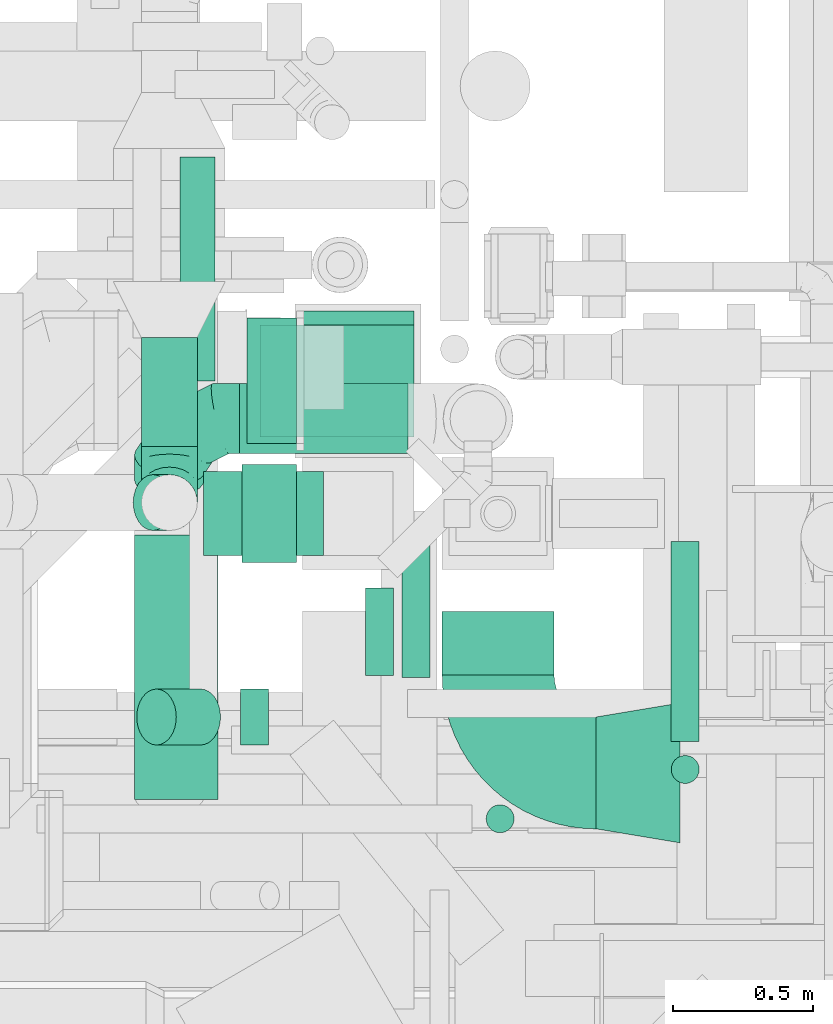
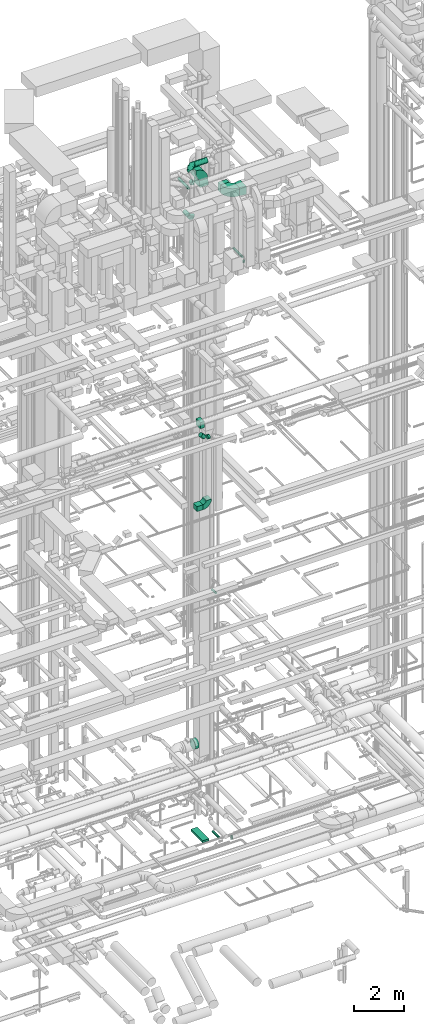
# One storey, part 234 of 337: 15 flow segments, 8 flow fittings.
"""IFC2X3 building model written with IfcOpenShell, lengths in millimetres."""

from ifc_helpers import new_model, entity, si_unit, converted_unit, derived_unit, direction, frame, frame_2d, origin, origin_2d_with_axis, place, context, subcontext, project, spatial, polyline, circle_curve, parameter, trimmed, segment, composite_curve, rectangle, circle, outline, extrude, faceted_brep, source, transform, mapped, material, type_object, type_shapes, element, save


model = new_model("IFC2X3")

# Units and contexts
model_context = context("Model", 3, precision=0.01, world=origin(), true_north=direction((6.12303176911189e-17, 1.0)))
body_context = subcontext(model_context, "Body", "Model", "MODEL_VIEW")
ifc_project = project(units=[si_unit("LENGTHUNIT", "METRE", prefix="MILLI"), si_unit("AREAUNIT", "SQUARE_METRE"), si_unit("VOLUMEUNIT", "CUBIC_METRE"), converted_unit("PLANEANGLEUNIT", "DEGREE", entity("IfcRatioMeasure", 0.0174532925199433), si_unit("PLANEANGLEUNIT", "RADIAN"), dimensions=[0, 0, 0, 0, 0, 0, 0]), si_unit("MASSUNIT", "GRAM", prefix="KILO"), derived_unit("MASSDENSITYUNIT", [(si_unit("MASSUNIT", "GRAM", prefix="KILO"), 1), (si_unit("LENGTHUNIT", "METRE"), -3)]), derived_unit("MOMENTOFINERTIAUNIT", [(si_unit("LENGTHUNIT", "METRE"), 4)]), si_unit("TIMEUNIT", "SECOND"), si_unit("FREQUENCYUNIT", "HERTZ"), si_unit("THERMODYNAMICTEMPERATUREUNIT", "DEGREE_CELSIUS"), derived_unit("THERMALTRANSMITTANCEUNIT", [(si_unit("MASSUNIT", "GRAM", prefix="KILO"), 1), (si_unit("THERMODYNAMICTEMPERATUREUNIT", "KELVIN"), -1), (si_unit("TIMEUNIT", "SECOND"), -3)]), derived_unit("VOLUMETRICFLOWRATEUNIT", [(si_unit("LENGTHUNIT", "METRE"), 3), (si_unit("TIMEUNIT", "SECOND"), -1)]), derived_unit("MASSFLOWRATEUNIT", [(si_unit("MASSUNIT", "GRAM", prefix="KILO"), 1), (si_unit("TIMEUNIT", "SECOND"), -1)]), derived_unit("ROTATIONALFREQUENCYUNIT", [(si_unit("TIMEUNIT", "SECOND"), -1)]), si_unit("ELECTRICCURRENTUNIT", "AMPERE"), si_unit("ELECTRICVOLTAGEUNIT", "VOLT"), si_unit("POWERUNIT", "WATT"), si_unit("FORCEUNIT", "NEWTON", prefix="KILO"), si_unit("ILLUMINANCEUNIT", "LUX"), si_unit("LUMINOUSFLUXUNIT", "LUMEN"), si_unit("LUMINOUSINTENSITYUNIT", "CANDELA"), derived_unit("USERDEFINED", [(si_unit("MASSUNIT", "GRAM", prefix="KILO"), -1), (si_unit("LENGTHUNIT", "METRE"), -2), (si_unit("TIMEUNIT", "SECOND"), 3), (si_unit("LUMINOUSFLUXUNIT", "LUMEN"), 1)]), derived_unit("LINEARVELOCITYUNIT", [(si_unit("LENGTHUNIT", "METRE"), 1), (si_unit("TIMEUNIT", "SECOND"), -1)]), si_unit("PRESSUREUNIT", "PASCAL"), derived_unit("USERDEFINED", [(si_unit("LENGTHUNIT", "METRE"), -2), (si_unit("MASSUNIT", "GRAM", prefix="KILO"), 1), (si_unit("TIMEUNIT", "SECOND"), -2)]), derived_unit("LINEARFORCEUNIT", [(si_unit("MASSUNIT", "GRAM", prefix="KILO"), 1), (si_unit("LENGTHUNIT", "METRE"), 1), (si_unit("TIMEUNIT", "SECOND"), -2), (si_unit("LENGTHUNIT", "METRE"), -1)]), derived_unit("PLANARFORCEUNIT", [(si_unit("MASSUNIT", "GRAM", prefix="KILO"), 1), (si_unit("LENGTHUNIT", "METRE"), 1), (si_unit("TIMEUNIT", "SECOND"), -2), (si_unit("LENGTHUNIT", "METRE"), -2)])], contexts=[model_context])

# Site, building, storey
site_placement = place(None, origin())
site = spatial("IfcSite", under=ifc_project, at=site_placement, CompositionType="ELEMENT")
building_placement = place(site_placement, origin())
building = spatial("IfcBuilding", under=site, at=building_placement, CompositionType="ELEMENT")
storey_placement = place(building_placement, origin())
storey = spatial("IfcBuildingStorey", under=building, at=storey_placement, CompositionType="ELEMENT", Elevation=0.0)

# Flow segments
duct_segment_type_1 = type_object("IfcDuctSegmentType", PredefinedType="NOTDEFINED")
flow_segment_1_placement = place(storey_placement, frame((58179.81, 9943.15, -625.0)))
element("IfcFlowSegment", 1, at=flow_segment_1_placement, inside=storey, type_object=duct_segment_type_1, context=body_context, shape_type="SweptSolid", body=[
    extrude(rectangle(XDim=944.720900000099, YDim=300.000000000001, at=origin_2d_with_axis()), frame((150.0, 472.36, 0.0), z_axis=(0.0, 0.0, 1.0), x_axis=(0.0, -1.0, 0.0)), (0.0, 0.0, 1.0), 100.0),
])
flow_segment_2_placement = place(storey_placement, frame((58427.28, 10815.63, 15000.0)))
element("IfcFlowSegment", 2, at=flow_segment_2_placement, inside=storey, type_object=duct_segment_type_1, context=body_context, shape_type="SweptSolid", body=[
    extrude(rectangle(XDim=278.095766639909, YDim=299.999999999999, at=origin_2d_with_axis()), frame((139.05, 150.0, 0.0), z_axis=(0.0, 0.0, 1.0), x_axis=(-1.0, 0.0, 0.0)), (0.0, 0.0, 1.0), 249.999999999999),
])
flow_segment_3_placement = place(storey_placement, frame((58564.44, 10789.64, 19034.58)))
element("IfcFlowSegment", 3, at=flow_segment_3_placement, inside=storey, type_object=duct_segment_type_1, context=body_context, shape_type="SweptSolid", body=[
    extrude(rectangle(XDim=195.941978523179, YDim=350.000000000001, at=origin_2d_with_axis()), frame((97.97, 175.0, 0.0)), (0.0, 0.0, 1.0), 300.000000000001),
])
flow_segment_4_placement = place(storey_placement, frame((59280.56, 10387.5, 30600.0)))
element("IfcFlowSegment", 4, at=flow_segment_4_placement, inside=storey, type_object=duct_segment_type_1, context=body_context, shape_type="SweptSolid", body=[
    extrude(rectangle(XDim=227.130410000165, YDim=399.999999999996, at=origin_2d_with_axis()), frame((200.0, 113.57, 0.0), z_axis=(0.0, 0.0, 1.0), x_axis=(0.0, 1.0, 0.0)), (0.0, 0.0, 1.0), 400.000000000004),
])
duct_segment_type_2 = type_object("IfcDuctSegmentType", PredefinedType="NOTDEFINED")
flow_segment_5_placement = place(storey_placement, frame((59436.1, 9821.97, -850.0)))
element("IfcFlowSegment", 5, at=flow_segment_5_placement, inside=storey, type_object=duct_segment_type_2, context=body_context, shape_type="SweptSolid", body=[
    extrude(circle(Radius=50.0, at=origin_2d_with_axis()), frame((51.6, 51.6, 0.0), z_axis=(0.0, 0.0, 1.0), x_axis=(-1.0, 0.0, 0.0)), (0.0, 0.0, 1.0), 170.0),
])
flow_segment_6_placement = place(storey_placement, frame((59135.22, 10378.7, -1026.6)))
element("IfcFlowSegment", 6, at=flow_segment_6_placement, inside=storey, type_object=duct_segment_type_2, context=body_context, shape_type="SweptSolid", body=[
    extrude(circle(Radius=50.0, at=origin_2d_with_axis()), frame((51.6, 0.0, 51.6), z_axis=(0.0, 1.0, 0.0), x_axis=(-1.0, 0.0, 0.0)), (0.0, 0.0, 1.0), 485.932210000001),
])
flow_segment_7_placement = place(storey_placement, frame((58582.17, 11212.98, 2939.23)))
element("IfcFlowSegment", 7, at=flow_segment_7_placement, inside=storey, type_object=duct_segment_type_2, context=body_context, shape_type="SweptSolid", body=[
    extrude(circle(Radius=225.0, at=origin_2d_with_axis()), frame((0.0, 226.6, 226.6), z_axis=(1.0, 0.0, 0.0), x_axis=(0.0, -1.0, 0.0)), (0.0, 0.0, 1.0), 177.728025964379),
])
flow_segment_8_placement = place(storey_placement, frame((59004.19, 10386.33, 10998.4)))
element("IfcFlowSegment", 8, at=flow_segment_8_placement, inside=storey, type_object=duct_segment_type_2, context=body_context, shape_type="SweptSolid", body=[
    extrude(circle(Radius=50.0, at=origin_2d_with_axis()), frame((51.6, 0.0, 51.6), z_axis=(0.0, 1.0, 0.0), x_axis=(-1.0, 0.0, 0.0)), (0.0, 0.0, 1.0), 313.317479908698),
])
flow_segment_9_placement = place(storey_placement, frame((58558.56, 10135.8, 18873.22)))
element("IfcFlowSegment", 9, at=flow_segment_9_placement, inside=storey, type_object=duct_segment_type_2, context=body_context, shape_type="SweptSolid", body=[
    extrude(circle(Radius=100.0, at=origin_2d_with_axis()), frame((0.0, 101.6, 101.6), z_axis=(1.0, 0.0, 0.0), x_axis=(0.0, 1.0, 0.0)), (0.0, 0.0, 1.0), 100.46959287631),
])
flow_segment_10_placement = place(storey_placement, frame((58186.8, 10135.8, 18961.09)))
element("IfcFlowSegment", 10, at=flow_segment_10_placement, inside=storey, type_object=duct_segment_type_2, context=body_context, shape_type="SweptSolid", body=[
    extrude(circle(Radius=100.0, at=origin_2d_with_axis()), frame((230.33, 101.6, 72.31), z_axis=(-0.707106781186548, 0.0, 0.707106781186548), x_axis=(0.0, 1.0, 0.0)), (0.0, 0.0, 1.0), 223.484445150657),
])
flow_segment_11_placement = place(storey_placement, frame((60097.92, 10149.93, 27248.4)))
element("IfcFlowSegment", 11, at=flow_segment_11_placement, inside=storey, type_object=duct_segment_type_2, context=body_context, shape_type="SweptSolid", body=[
    extrude(circle(Radius=50.0, at=origin_2d_with_axis()), frame((51.6, 0.0, 51.6), z_axis=(0.0, 1.0, 0.0), x_axis=(-1.0, 0.0, 0.0)), (0.0, 0.0, 1.0), 714.700000000041),
])
flow_segment_12_placement = place(storey_placement, frame((58340.94, 11438.43, 30433.4)))
element("IfcFlowSegment", 12, at=flow_segment_12_placement, inside=storey, type_object=duct_segment_type_2, context=body_context, shape_type="SweptSolid", body=[
    extrude(circle(Radius=62.5, at=origin_2d_with_axis()), frame((64.1, 0.0, 64.1), z_axis=(0.0, 1.0, 0.0), x_axis=(1.0, 0.0, 0.0)), (0.0, 0.0, 1.0), 800.886516975034),
])
flow_segment_13_placement = place(storey_placement, frame((58203.44, 11204.22, 29198.4)))
element("IfcFlowSegment", 13, at=flow_segment_13_placement, inside=storey, type_object=duct_segment_type_2, context=body_context, shape_type="SweptSolid", body=[
    extrude(circle(Radius=100.0, at=origin_2d_with_axis()), frame((101.6, 0.0, 101.6), z_axis=(0.0, 1.0, 0.0), x_axis=(-1.0, 0.0, 0.0)), (0.0, 0.0, 1.0), 390.042378695762),
])
flow_segment_14_placement = place(storey_placement, frame((60097.92, 9998.34, 27100.0)))
element("IfcFlowSegment", 14, at=flow_segment_14_placement, inside=storey, type_object=duct_segment_type_2, context=body_context, shape_type="SweptSolid", body=[
    extrude(circle(Radius=50.0, at=origin_2d_with_axis()), frame((51.6, 51.6, 0.0)), (0.0, 0.0, 1.0), 100.000000000003),
])
flow_segment_15_placement = place(storey_placement, frame((58555.03, 11177.59, 31573.0)))
element("IfcFlowSegment", 15, at=flow_segment_15_placement, inside=storey, type_object=duct_segment_type_2, context=body_context, shape_type="SweptSolid", body=[
    extrude(circle(Radius=125.0, at=origin_2d_with_axis()), frame((0.0, 126.6, 126.6), z_axis=(1.0, 0.0, 0.0), x_axis=(0.0, -1.0, 0.0)), (0.0, 0.0, 1.0), 603.905820001532),
])

# Flow fittings
ifc_material = material()
duct_fitting_type_1 = type_object("IfcDuctFittingType", PredefinedType="NOTDEFINED", material=ifc_material)
shared_shape_1 = source(origin(), body_context, "Body", "SweptSolid", [
    extrude(outline(polyline([(-189.06, -221.94), (115.08, -221.94), (180.84, 172.62), (-106.86, 271.26), (-189.06, -221.94)])), frame((150.0, 0.0, -200.0), z_axis=(0.0, 0.0, 1.0), x_axis=(0.986393923832144, 0.164398987305356, 0.0)), (0.0, 0.0, 1.0), 400.0),
])
type_shapes(duct_fitting_type_1, [shared_shape_1])
flow_fitting_1_placement = place(storey_placement, frame((60130.56, 10037.5, 30800.0), z_axis=(-1.35908083349201e-08, 0.0, 1.0), x_axis=(-1.0, 0.0, -1.35908083349201e-08)))
element("IfcFlowFitting", 16, at=flow_fitting_1_placement, inside=storey, type_object=duct_fitting_type_1, material=ifc_material, context=body_context, shape_type="MappedRepresentation", body=[
    mapped(shared_shape_1, transform((0.0, 0.0, 0.0), scale=1.0)),
])
duct_fitting_type_2 = type_object("IfcDuctFittingType", PredefinedType="NOTDEFINED", material=ifc_material)
shared_shape_2 = source(origin(), body_context, "Body", "SweptSolid", [
    extrude(outline(polyline([(-200.0, -150.0), (200.0, -150.0), (250.0, 150.0), (-250.0, 150.0), (-200.0, -150.0)])), frame((150.0, 0.0, -200.0), z_axis=(0.0, 0.0, 1.0), x_axis=(0.0, -1.0, 0.0)), (0.0, 0.0, 1.0), 400.0),
])
type_shapes(duct_fitting_type_2, [shared_shape_2])
flow_fitting_2_placement = place(storey_placement, frame((58979.9, 11439.32, 30850.0), z_axis=(1.0, 0.0, 0.0), x_axis=(0.0, 0.0, -1.0)))
element("IfcFlowFitting", 17, at=flow_fitting_2_placement, inside=storey, type_object=duct_fitting_type_2, material=ifc_material, context=body_context, shape_type="MappedRepresentation", body=[
    mapped(shared_shape_2, transform((0.0, 0.0, 0.0), scale=1.0)),
])
duct_fitting_type_3 = type_object("IfcDuctFittingType", PredefinedType="NOTDEFINED", material=ifc_material)
shared_shape_3 = source(origin(), body_context, "Body", "Brep", [
    faceted_brep([(-250.0, 0.0, -125.0), (-250.0, -32.35, -120.74), (-250.0, -62.5, -108.25), (-250.0, -88.39, -88.39), (-250.0, -108.25, -62.5), (-250.0, -120.74, -32.35), (-250.0, -125.0, 0.0), (-250.0, -120.74, 32.35), (-250.0, -108.25, 62.5), (-250.0, -88.39, 88.39), (-250.0, -62.5, 108.25), (-250.0, -32.35, 120.74), (-250.0, 0.0, 125.0), (-250.0, 32.35, 120.74), (-250.0, 62.5, 108.25), (-250.0, 88.39, 88.39), (-250.0, 108.25, 62.5), (-250.0, 120.74, 32.35), (-250.0, 125.0, 0.0), (-250.0, 120.74, -32.35), (-250.0, 108.25, -62.5), (-250.0, 88.39, -88.39), (-250.0, 62.5, -108.25), (-250.0, 32.35, -120.74), (-191.68, 32.35, 120.74), (-199.76, 62.5, 108.25), (-183.01, 0.0, 125.0), (-206.7, 88.39, 88.39), (-215.37, 120.74, 32.35), (-216.51, 125.0, 0.0), (-212.02, 108.25, 62.5), (-212.02, 108.25, -62.5), (-206.7, 88.39, -88.39), (-215.37, 120.74, -32.35), (-191.68, 32.35, -120.74), (-183.01, 0.0, -125.0), (-199.76, 62.5, -108.25), (-174.34, -32.35, -120.74), (-166.27, -62.5, -108.25), (-159.33, -88.39, -88.39), (-154.01, -108.25, -62.5), (-150.66, -120.74, -32.35), (-149.52, -125.0, 0.0), (-150.66, -120.74, 32.35), (-154.01, -108.25, 62.5), (-159.33, -88.39, 88.39), (-166.27, -62.5, 108.25), (-174.34, -32.35, 120.74), (-90.67, 90.67, 120.74), (-112.74, 112.74, 108.25), (-66.99, 66.99, 125.0), (-131.69, 131.69, 88.39), (-146.23, 146.23, 62.5), (-155.38, 155.38, 32.35), (-158.49, 158.49, 0.0), (-155.38, 155.38, -32.35), (-146.23, 146.23, -62.5), (-131.69, 131.69, -88.39), (-90.67, 90.67, -120.74), (-66.99, 66.99, -125.0), (-112.74, 112.74, -108.25), (-43.3, 43.3, -120.74), (-21.23, 21.23, -108.25), (-2.28, 2.28, -88.39), (12.26, -12.26, -62.5), (21.4, -21.4, -32.35), (24.52, -24.52, 0.0), (21.4, -21.4, 32.35), (12.26, -12.26, 62.5), (-2.28, 2.28, 88.39), (-21.23, 21.23, 108.25), (-43.3, 43.3, 120.74), (-32.35, 191.68, 120.74), (-62.5, 199.76, 108.25), (0.0, 183.01, 125.0), (-88.39, 206.7, 88.39), (-108.25, 212.02, 62.5), (-120.74, 215.37, 32.35), (-125.0, 216.51, 0.0), (-120.74, 215.37, -32.35), (-108.25, 212.02, -62.5), (-88.39, 206.7, -88.39), (-32.35, 191.68, -120.74), (0.0, 183.01, -125.0), (-62.5, 199.76, -108.25), (32.35, 174.34, -120.74), (62.5, 166.27, -108.25), (88.39, 159.33, -88.39), (108.25, 154.01, -62.5), (120.74, 150.66, -32.35), (125.0, 149.52, 0.0), (120.74, 150.66, 32.35), (108.25, 154.01, 62.5), (88.39, 159.33, 88.39), (62.5, 166.27, 108.25), (32.35, 174.34, 120.74), (-32.35, 250.0, -120.74), (-62.5, 250.0, -108.25), (-88.39, 250.0, -88.39), (-108.25, 250.0, -62.5), (-120.74, 250.0, -32.35), (-125.0, 250.0, 0.0), (-120.74, 250.0, 32.35), (-108.25, 250.0, 62.5), (-88.39, 250.0, 88.39), (-62.5, 250.0, 108.25), (-32.35, 250.0, 120.74), (0.0, 250.0, 125.0), (32.35, 250.0, 120.74), (62.5, 250.0, 108.25), (88.39, 250.0, 88.39), (108.25, 250.0, 62.5), (120.74, 250.0, 32.35), (125.0, 250.0, 0.0), (120.74, 250.0, -32.35), (108.25, 250.0, -62.5), (88.39, 250.0, -88.39), (62.5, 250.0, -108.25), (32.35, 250.0, -120.74), (0.0, 250.0, -125.0)], [[[0, 1, 2, 3, 4, 5, 6, 7, 8, 9, 10, 11, 12, 13, 14, 15, 16, 17, 18, 19, 20, 21, 22, 23]], [[24, 25, 14, 13]], [[26, 24, 13, 12]], [[14, 25, 27, 15]], [[28, 29, 18, 17]], [[30, 28, 17, 16]], [[15, 27, 30, 16]], [[20, 31, 32, 21]], [[33, 31, 20, 19]], [[18, 29, 33, 19]], [[34, 35, 0, 23]], [[36, 34, 23, 22]], [[21, 32, 36, 22]], [[1, 0, 35, 37]], [[2, 1, 37, 38]], [[38, 39, 3, 2]], [[5, 4, 40, 41]], [[6, 5, 41, 42]], [[39, 40, 4, 3]], [[6, 42, 43, 7]], [[7, 43, 44, 8]], [[8, 44, 45, 9]], [[9, 45, 46, 10]], [[10, 46, 47, 11]], [[26, 12, 11, 47]], [[48, 49, 25, 24]], [[50, 48, 24, 26]], [[27, 25, 49, 51]], [[52, 53, 28, 30]], [[51, 52, 30, 27]], [[29, 28, 53, 54]], [[55, 56, 31, 33]], [[54, 55, 33, 29]], [[32, 31, 56, 57]], [[58, 59, 35, 34]], [[60, 58, 34, 36]], [[57, 60, 36, 32]], [[37, 35, 59, 61]], [[38, 37, 61, 62]], [[39, 38, 62, 63]], [[41, 40, 64, 65]], [[42, 41, 65, 66]], [[63, 64, 40, 39]], [[43, 42, 66, 67]], [[44, 43, 67, 68]], [[68, 69, 45, 44]], [[46, 45, 69, 70]], [[47, 46, 70, 71]], [[26, 47, 71, 50]], [[72, 73, 49, 48]], [[74, 72, 48, 50]], [[51, 49, 73, 75]], [[76, 77, 53, 52]], [[75, 76, 52, 51]], [[54, 53, 77, 78]], [[79, 80, 56, 55]], [[78, 79, 55, 54]], [[57, 56, 80, 81]], [[82, 83, 59, 58]], [[84, 82, 58, 60]], [[81, 84, 60, 57]], [[61, 59, 83, 85]], [[62, 61, 85, 86]], [[63, 62, 86, 87]], [[65, 64, 88, 89]], [[66, 65, 89, 90]], [[87, 88, 64, 63]], [[67, 66, 90, 91]], [[68, 67, 91, 92]], [[92, 93, 69, 68]], [[70, 69, 93, 94]], [[71, 70, 94, 95]], [[50, 71, 95, 74]], [[96, 97, 98, 99, 100, 101, 102, 103, 104, 105, 106, 107, 108, 109, 110, 111, 112, 113, 114, 115, 116, 117, 118, 119]], [[72, 74, 107, 106]], [[73, 72, 106, 105]], [[75, 73, 105, 104]], [[77, 76, 103, 102]], [[78, 77, 102, 101]], [[75, 104, 103, 76]], [[78, 101, 100, 79]], [[79, 100, 99, 80]], [[80, 99, 98, 81]], [[84, 97, 96, 82]], [[82, 96, 119, 83]], [[84, 81, 98, 97]], [[83, 119, 118, 85]], [[85, 118, 117, 86]], [[116, 87, 86, 117]], [[88, 115, 114, 89]], [[89, 114, 113, 90]], [[115, 88, 87, 116]], [[91, 90, 113, 112]], [[92, 91, 112, 111]], [[111, 110, 93, 92]], [[95, 94, 109, 108]], [[74, 95, 108, 107]], [[110, 109, 94, 93]]]),
])
type_shapes(duct_fitting_type_3, [shared_shape_3])
flow_fitting_3_placement = place(storey_placement, frame((58305.03, 11304.18, 31699.6), z_axis=(0.0, -0.494669196848206, 0.86908134584143), x_axis=(-1.0, 0.0, 0.0)))
element("IfcFlowFitting", 18, at=flow_fitting_3_placement, inside=storey, type_object=duct_fitting_type_3, material=ifc_material, context=body_context, shape_type="MappedRepresentation", body=[
    mapped(shared_shape_3, transform((0.0, 0.0, 0.0), scale=1.0)),
])
duct_fitting_type_4 = type_object("IfcDuctFittingType", PredefinedType="NOTDEFINED", material=ifc_material)
shared_shape_4 = source(origin(), body_context, "Body", "Brep", [
    faceted_brep([(-200.0, 0.0, -100.0), (-200.0, -25.88, -96.59), (-200.0, -50.0, -86.6), (-200.0, -70.71, -70.71), (-200.0, -86.6, -50.0), (-200.0, -96.59, -25.88), (-200.0, -100.0, 0.0), (-200.0, -96.59, 25.88), (-200.0, -86.6, 50.0), (-200.0, -70.71, 70.71), (-200.0, -50.0, 86.6), (-200.0, -25.88, 96.59), (-200.0, 0.0, 100.0), (-200.0, 25.88, 96.59), (-200.0, 50.0, 86.6), (-200.0, 70.71, 70.71), (-200.0, 86.6, 50.0), (-200.0, 96.59, 25.88), (-200.0, 100.0, 0.0), (-200.0, 96.59, -25.88), (-200.0, 86.6, -50.0), (-200.0, 70.71, -70.71), (-200.0, 50.0, -86.6), (-200.0, 25.88, -96.59), (-153.35, 25.88, 96.59), (-159.81, 50.0, 86.6), (-146.41, 0.0, 100.0), (-165.36, 70.71, 70.71), (-172.29, 96.59, 25.88), (-173.21, 100.0, 0.0), (-169.62, 86.6, 50.0), (-169.62, 86.6, -50.0), (-165.36, 70.71, -70.71), (-172.29, 96.59, -25.88), (-153.35, 25.88, -96.59), (-146.41, 0.0, -100.0), (-159.81, 50.0, -86.6), (-139.48, -25.88, -96.59), (-133.01, -50.0, -86.6), (-127.46, -70.71, -70.71), (-123.21, -86.6, -50.0), (-120.53, -96.59, -25.88), (-119.62, -100.0, 0.0), (-120.53, -96.59, 25.88), (-123.21, -86.6, 50.0), (-127.46, -70.71, 70.71), (-133.01, -50.0, 86.6), (-139.48, -25.88, 96.59), (-72.54, 72.54, 96.59), (-90.19, 90.19, 86.6), (-53.59, 53.59, 100.0), (-105.35, 105.35, 70.71), (-116.99, 116.99, 50.0), (-124.3, 124.3, 25.88), (-126.79, 126.79, 0.0), (-124.3, 124.3, -25.88), (-116.99, 116.99, -50.0), (-105.35, 105.35, -70.71), (-72.54, 72.54, -96.59), (-53.59, 53.59, -100.0), (-90.19, 90.19, -86.6), (-34.64, 34.64, -96.59), (-16.99, 16.99, -86.6), (-1.83, 1.83, -70.71), (9.81, -9.81, -50.0), (17.12, -17.12, -25.88), (19.62, -19.62, 0.0), (17.12, -17.12, 25.88), (9.81, -9.81, 50.0), (-1.83, 1.83, 70.71), (-16.99, 16.99, 86.6), (-34.64, 34.64, 96.59), (-25.88, 153.35, 96.59), (-50.0, 159.81, 86.6), (0.0, 146.41, 100.0), (-70.71, 165.36, 70.71), (-86.6, 169.62, 50.0), (-96.59, 172.29, 25.88), (-100.0, 173.21, 0.0), (-96.59, 172.29, -25.88), (-86.6, 169.62, -50.0), (-70.71, 165.36, -70.71), (-25.88, 153.35, -96.59), (0.0, 146.41, -100.0), (-50.0, 159.81, -86.6), (25.88, 139.48, -96.59), (50.0, 133.01, -86.6), (70.71, 127.46, -70.71), (86.6, 123.21, -50.0), (96.59, 120.53, -25.88), (100.0, 119.62, 0.0), (96.59, 120.53, 25.88), (86.6, 123.21, 50.0), (70.71, 127.46, 70.71), (50.0, 133.01, 86.6), (25.88, 139.48, 96.59), (-25.88, 200.0, -96.59), (-50.0, 200.0, -86.6), (-70.71, 200.0, -70.71), (-86.6, 200.0, -50.0), (-96.59, 200.0, -25.88), (-100.0, 200.0, 0.0), (-96.59, 200.0, 25.88), (-86.6, 200.0, 50.0), (-70.71, 200.0, 70.71), (-50.0, 200.0, 86.6), (-25.88, 200.0, 96.59), (0.0, 200.0, 100.0), (25.88, 200.0, 96.59), (50.0, 200.0, 86.6), (70.71, 200.0, 70.71), (86.6, 200.0, 50.0), (96.59, 200.0, 25.88), (100.0, 200.0, 0.0), (96.59, 200.0, -25.88), (86.6, 200.0, -50.0), (70.71, 200.0, -70.71), (50.0, 200.0, -86.6), (25.88, 200.0, -96.59), (0.0, 200.0, -100.0)], [[[0, 1, 2, 3, 4, 5, 6, 7, 8, 9, 10, 11, 12, 13, 14, 15, 16, 17, 18, 19, 20, 21, 22, 23]], [[24, 25, 14, 13]], [[26, 24, 13, 12]], [[14, 25, 27, 15]], [[28, 29, 18, 17]], [[30, 28, 17, 16]], [[15, 27, 30, 16]], [[20, 31, 32, 21]], [[33, 31, 20, 19]], [[18, 29, 33, 19]], [[34, 35, 0, 23]], [[36, 34, 23, 22]], [[32, 36, 22, 21]], [[1, 0, 35, 37]], [[2, 1, 37, 38]], [[38, 39, 3, 2]], [[5, 4, 40, 41]], [[6, 5, 41, 42]], [[39, 40, 4, 3]], [[6, 42, 43, 7]], [[7, 43, 44, 8]], [[8, 44, 45, 9]], [[9, 45, 46, 10]], [[10, 46, 47, 11]], [[26, 12, 11, 47]], [[48, 49, 25, 24]], [[50, 48, 24, 26]], [[27, 25, 49, 51]], [[52, 53, 28, 30]], [[51, 52, 30, 27]], [[29, 28, 53, 54]], [[55, 56, 31, 33]], [[54, 55, 33, 29]], [[32, 31, 56, 57]], [[58, 59, 35, 34]], [[60, 58, 34, 36]], [[57, 60, 36, 32]], [[37, 35, 59, 61]], [[38, 37, 61, 62]], [[39, 38, 62, 63]], [[41, 40, 64, 65]], [[42, 41, 65, 66]], [[63, 64, 40, 39]], [[43, 42, 66, 67]], [[44, 43, 67, 68]], [[68, 69, 45, 44]], [[46, 45, 69, 70]], [[47, 46, 70, 71]], [[26, 47, 71, 50]], [[72, 73, 49, 48]], [[74, 72, 48, 50]], [[51, 49, 73, 75]], [[76, 77, 53, 52]], [[75, 76, 52, 51]], [[54, 53, 77, 78]], [[79, 80, 56, 55]], [[78, 79, 55, 54]], [[57, 56, 80, 81]], [[82, 83, 59, 58]], [[84, 82, 58, 60]], [[81, 84, 60, 57]], [[61, 59, 83, 85]], [[62, 61, 85, 86]], [[63, 62, 86, 87]], [[65, 64, 88, 89]], [[66, 65, 89, 90]], [[87, 88, 64, 63]], [[67, 66, 90, 91]], [[68, 67, 91, 92]], [[92, 93, 69, 68]], [[70, 69, 93, 94]], [[71, 70, 94, 95]], [[50, 71, 95, 74]], [[96, 97, 98, 99, 100, 101, 102, 103, 104, 105, 106, 107, 108, 109, 110, 111, 112, 113, 114, 115, 116, 117, 118, 119]], [[72, 74, 107, 106]], [[73, 72, 106, 105]], [[75, 73, 105, 104]], [[102, 101, 78, 77]], [[103, 102, 77, 76]], [[75, 104, 103, 76]], [[78, 101, 100, 79]], [[79, 100, 99, 80]], [[80, 99, 98, 81]], [[84, 97, 96, 82]], [[82, 96, 119, 83]], [[84, 81, 98, 97]], [[118, 117, 86, 85]], [[119, 118, 85, 83]], [[116, 87, 86, 117]], [[88, 115, 114, 89]], [[89, 114, 113, 90]], [[115, 88, 87, 116]], [[91, 90, 113, 112]], [[92, 91, 112, 111]], [[111, 110, 93, 92]], [[95, 94, 109, 108]], [[74, 95, 108, 107]], [[110, 109, 94, 93]]]),
])
type_shapes(duct_fitting_type_4, [shared_shape_4])
flow_fitting_4_placement = place(storey_placement, frame((58305.03, 11004.22, 29300.0), z_axis=(-1.0, 0.0, 0.0), x_axis=(0.0, -1.0, 0.0)))
element("IfcFlowFitting", 19, at=flow_fitting_4_placement, inside=storey, type_object=duct_fitting_type_4, material=ifc_material, context=body_context, shape_type="MappedRepresentation", body=[
    mapped(shared_shape_4, transform((0.0, 0.0, 0.0), scale=1.0)),
])
duct_fitting_type_5 = type_object("IfcDuctFittingType", PredefinedType="NOTDEFINED", material=ifc_material)
shared_shape_5 = source(origin(), body_context, "Body", "Brep", [
    faceted_brep([(-82.84, 0.0, -100.0), (-82.84, -25.88, -96.59), (-82.84, -50.0, -86.6), (-82.84, -70.71, -70.71), (-82.84, -86.6, -50.0), (-82.84, -96.59, -25.88), (-82.84, -100.0, 0.0), (-82.84, -96.59, 25.88), (-82.84, -86.6, 50.0), (-82.84, -70.71, 70.71), (-82.84, -50.0, 86.6), (-82.84, -25.88, 96.59), (-82.84, 0.0, 100.0), (-82.84, 25.88, 96.59), (-82.84, 50.0, 86.6), (-82.84, 70.71, 70.71), (-82.84, 86.6, 50.0), (-82.84, 96.59, 25.88), (-82.84, 100.0, 0.0), (-82.84, 96.59, -25.88), (-82.84, 86.6, -50.0), (-82.84, 70.71, -70.71), (-82.84, 50.0, -86.6), (-82.84, 25.88, -96.59), (-10.72, 25.88, 96.59), (-20.71, 50.0, 86.6), (0.0, 0.0, 100.0), (-29.29, 70.71, 70.71), (-35.87, 86.6, 50.0), (-40.01, 96.59, 25.88), (-41.42, 100.0, 0.0), (-40.01, 96.59, -25.88), (-35.87, 86.6, -50.0), (-29.29, 70.71, -70.71), (-10.72, 25.88, -96.59), (0.0, 0.0, -100.0), (-20.71, 50.0, -86.6), (10.72, -25.88, -96.59), (20.71, -50.0, -86.6), (29.29, -70.71, -70.71), (35.87, -86.6, -50.0), (40.01, -96.59, -25.88), (41.42, -100.0, 0.0), (40.01, -96.59, 25.88), (35.87, -86.6, 50.0), (29.29, -70.71, 70.71), (20.71, -50.0, 86.6), (10.72, -25.88, 96.59), (58.58, 58.58, 100.0), (40.28, 76.88, 96.59), (23.22, 93.93, 86.6), (8.58, 108.58, 70.71), (-2.66, 119.82, 50.0), (-9.72, 126.88, 25.88), (-12.13, 129.29, 0.0), (-9.72, 126.88, -25.88), (-2.66, 119.82, -50.0), (8.58, 108.58, -70.71), (23.22, 93.93, -86.6), (40.28, 76.88, -96.59), (58.58, 58.58, -100.0), (76.88, 40.28, -96.59), (93.93, 23.22, -86.6), (108.58, 8.58, -70.71), (119.82, -2.66, -50.0), (126.88, -9.72, -25.88), (129.29, -12.13, 0.0), (126.88, -9.72, 25.88), (119.82, -2.66, 50.0), (108.58, 8.58, 70.71), (93.93, 23.22, 86.6), (76.88, 40.28, 96.59)], [[[0, 1, 2, 3, 4, 5, 6, 7, 8, 9, 10, 11, 12, 13, 14, 15, 16, 17, 18, 19, 20, 21, 22, 23]], [[24, 25, 14, 13]], [[26, 24, 13, 12]], [[14, 25, 27, 15]], [[28, 29, 17, 16]], [[28, 16, 15, 27]], [[30, 18, 17, 29]], [[31, 32, 20, 19]], [[30, 31, 19, 18]], [[32, 33, 21, 20]], [[34, 35, 0, 23]], [[36, 34, 23, 22]], [[33, 36, 22, 21]], [[1, 0, 35, 37]], [[2, 1, 37, 38]], [[38, 39, 3, 2]], [[5, 4, 40, 41]], [[6, 5, 41, 42]], [[39, 40, 4, 3]], [[6, 42, 43, 7]], [[7, 43, 44, 8]], [[8, 44, 45, 9]], [[9, 45, 46, 10]], [[10, 46, 47, 11]], [[26, 12, 11, 47]], [[24, 26, 48, 49]], [[25, 24, 49, 50]], [[27, 25, 50, 51]], [[29, 28, 52, 53]], [[30, 29, 53, 54]], [[51, 52, 28, 27]], [[30, 54, 55, 31]], [[31, 55, 56, 32]], [[57, 33, 32, 56]], [[36, 58, 59, 34]], [[34, 59, 60, 35]], [[58, 36, 33, 57]], [[35, 60, 61, 37]], [[37, 61, 62, 38]], [[63, 39, 38, 62]], [[40, 64, 65, 41]], [[41, 65, 66, 42]], [[64, 40, 39, 63]], [[43, 42, 66, 67]], [[44, 43, 67, 68]], [[68, 69, 45, 44]], [[47, 46, 70, 71]], [[26, 47, 71, 48]], [[69, 70, 46, 45]], [[59, 58, 57, 56, 55, 54, 53, 52, 51, 50, 49, 48, 71, 70, 69, 68, 67, 66, 65, 64, 63, 62, 61, 60]]]),
])
type_shapes(duct_fitting_type_5, [shared_shape_5])
flow_fitting_5_placement = place(storey_placement, frame((58305.03, 11004.22, 31100.0), z_axis=(0.0, -1.0, 0.0), x_axis=(0.0, 0.0, 1.0)))
element("IfcFlowFitting", 20, at=flow_fitting_5_placement, inside=storey, type_object=duct_fitting_type_5, material=ifc_material, context=body_context, shape_type="MappedRepresentation", body=[
    mapped(shared_shape_5, transform((0.0, 0.0, 0.0), scale=1.0)),
])
duct_fitting_type_6 = type_object("IfcDuctFittingType", PredefinedType="NOTDEFINED", material=ifc_material)
shared_shape_6 = source(origin(), body_context, "Body", "SweptSolid", [
    extrude(outline(composite_curve([segment(polyline([(-375.0, -175.0), (25.0, -175.0)]), True, "CONTINUOUS"), segment(trimmed(circle_curve(frame_2d((175.0, -175.0), x_axis=(0.0, 1.0)), 150.0), [parameter(0.0)], [parameter(90.0)], True, "PARAMETER"), False, "CONTINUOUS"), segment(polyline([(175.0, -25.0), (175.0, 375.0)]), True, "CONTINUOUS"), segment(trimmed(circle_curve(frame_2d((175.0, -175.0), x_axis=(0.0, 1.0)), 550.0), [parameter(0.0)], [parameter(90.0)], True, "PARAMETER"), True, "CONTINUOUS")], self_intersect=False)), frame((-175.0, 175.0, -200.0), z_axis=(0.0, 0.0, 1.0), x_axis=(-1.0, 0.0, 0.0)), (0.0, 0.0, 1.0), 400.0),
])
type_shapes(duct_fitting_type_6, [shared_shape_6])
for number, where, z_axis, x_axis in (
    (21, (59480.56, 10037.5, 30800.0), (-1.35908083349201e-08, 0.0, 1.0), (0.0, -1.0, 0.0)),
    (22, (58979.9, 11439.32, 31200.0), (0.0, -1.0, 0.0), (0.0, 0.0, 1.0)),
):
    element("IfcFlowFitting", number, at=place(storey_placement, frame(where, z_axis=z_axis, x_axis=x_axis)), inside=storey, type_object=duct_fitting_type_6, material=ifc_material, context=body_context, shape_type="MappedRepresentation", body=[
        mapped(shared_shape_6, transform((0.0, 0.0, 0.0), scale=1.0)),
    ])
duct_fitting_type_7 = type_object("IfcDuctFittingType", PredefinedType="NOTDEFINED", material=ifc_material)
shared_shape_7 = source(origin(), body_context, "Body", "SweptSolid", [
    extrude(outline(composite_curve([segment(polyline([(-262.5, -137.5), (-12.5, -137.5)]), True, "CONTINUOUS"), segment(trimmed(circle_curve(frame_2d((137.5, -137.5), x_axis=(0.0, 1.0)), 150.0), [parameter(0.0)], [parameter(90.0000000000001)], True, "PARAMETER"), False, "CONTINUOUS"), segment(polyline([(137.5, 12.5), (137.5, 262.5)]), True, "CONTINUOUS"), segment(trimmed(circle_curve(frame_2d((137.5, -137.5), x_axis=(0.0, 1.0)), 400.0), [parameter(0.0)], [parameter(90.0000000000001)], True, "PARAMETER"), True, "CONTINUOUS")], self_intersect=False)), frame((-137.5, 137.5, -150.0), z_axis=(0.0, 0.0, 1.0), x_axis=(-1.0, 0.0, 0.0)), (0.0, 0.0, 1.0), 300.0),
])
type_shapes(duct_fitting_type_7, [shared_shape_7])
flow_fitting_6_placement = place(storey_placement, frame((58980.38, 10965.63, 15125.0), z_axis=(0.0, -1.0, 0.0), x_axis=(1.0, 0.0, 0.0)))
element("IfcFlowFitting", 23, at=flow_fitting_6_placement, inside=storey, type_object=duct_fitting_type_7, material=ifc_material, context=body_context, shape_type="MappedRepresentation", body=[
    mapped(shared_shape_7, transform((0.0, 0.0, 0.0), scale=1.0)),
])

save(model, "model.ifc")
